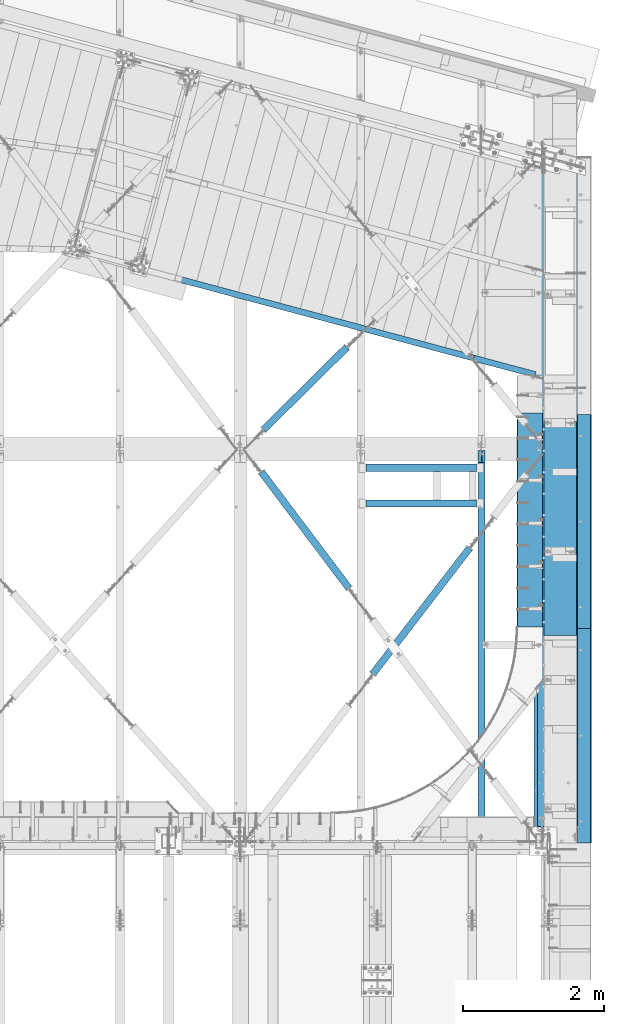
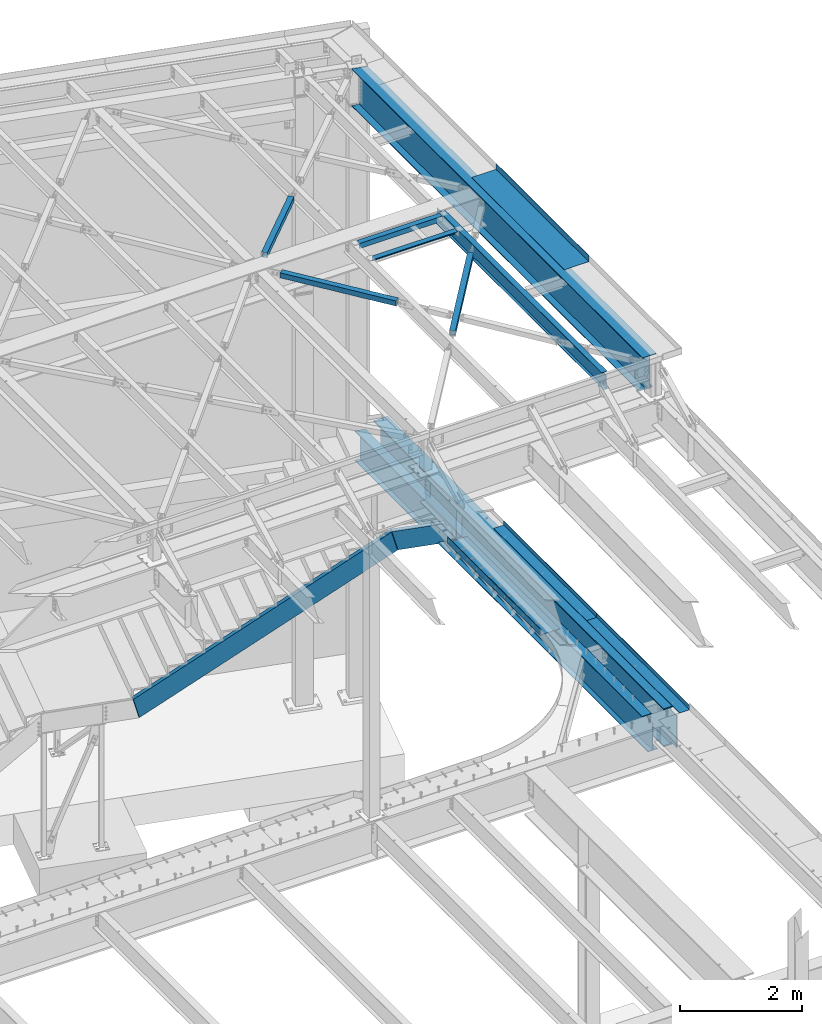
# One storey, part 1169 of 1763: 14 beams, 1 member, 9 elements without a shape of their own.
"""IFC2X3 building model written with IfcOpenShell, lengths in millimetres."""

from ifc_helpers import new_model, si_unit, frame, origin_with_axes, place, context, subcontext, project, spatial, faceted_brep, material, type_object, element, aggregate, save


model = new_model("IFC2X3")

# Units and contexts
model_context = context("Model", 3, precision=1e-05, world=origin_with_axes())
body_context = subcontext(model_context, "Body", "Model", "MODEL_VIEW")
ifc_project = project(units=[si_unit("LENGTHUNIT", "METRE", prefix="MILLI"), si_unit("AREAUNIT", "SQUARE_METRE"), si_unit("VOLUMEUNIT", "CUBIC_METRE"), si_unit("MASSUNIT", "GRAM", prefix="KILO"), si_unit("TIMEUNIT", "SECOND"), si_unit("PLANEANGLEUNIT", "RADIAN"), si_unit("SOLIDANGLEUNIT", "STERADIAN"), si_unit("THERMODYNAMICTEMPERATUREUNIT", "DEGREE_CELSIUS"), si_unit("LUMINOUSINTENSITYUNIT", "LUMEN")], contexts=[model_context])

# Site, building, storey
site_placement = place(None, origin_with_axes())
site = spatial("IfcSite", under=ifc_project, at=site_placement, CompositionType="ELEMENT")
building_placement = place(site_placement, origin_with_axes())
building = spatial("IfcBuilding", under=site, at=building_placement, Name="Undefined", CompositionType="ELEMENT")
storey_placement = place(building_placement, origin_with_axes())
storey = spatial("IfcBuildingStorey", under=building, at=storey_placement, Name="Undefined", CompositionType="ELEMENT", Elevation=0.0)

# Assembly, beams
assembly_1_placement = place(storey_placement, origin_with_axes())
assembly_1 = element("IfcElementAssembly", 1, at=assembly_1_placement, inside=storey, Name="FRAME", AssemblyPlace="NOTDEFINED", PredefinedType="RIGID_FRAME")
ifc_material_1 = material(Name="STEEL/A36")
beam_type_1 = type_object("IfcBeamType", Name="L4X4X3/8", PredefinedType="NOTDEFINED")
beam_1_placement = place(assembly_1_placement, frame((-24191.6246174484, 56926.1625, 12395.2), z_axis=(0.0, -1.0, 0.0), x_axis=(1.0, 0.0, 0.0)))
beam_1 = element("IfcBeam", 2, at=beam_1_placement, type_object=beam_type_1, material=ifc_material_1, Name="FRAME", ObjectType="L4X4X3/8", context=body_context, shape_type="Brep", body=[
    faceted_brep([(-3.63797880709171e-11, 50.8000000000011, -50.8000000000538), (-1.96450855582952e-10, 50.8000000000393, 50.7999999999374), (1572.27, 50.7999999999993, 50.8000000000029), (1572.27, 50.7999999999993, -50.8000000000029), (0.0, 41.2749999999996, 50.7999999999993), (1572.27, 41.2749999999996, 50.8000000000029), (0.0, 41.2749999999996, -41.2750000000015), (1572.27, 41.2749999999996, -41.2750000000015), (0.0, -50.7999999999993, -41.2750000000015), (1572.27, -50.7999999999993, -41.2750000000015), (2.11002770811319e-10, -50.8000000000357, -50.799999999952), (1572.27, -50.7999999999993, -50.8000000000029)], [[[0, 1, 2, 3]], [[1, 4, 5, 2]], [[4, 6, 7, 5]], [[6, 8, 9, 7]], [[8, 10, 11, 9]], [[10, 0, 3, 11]], [[5, 7, 9, 11, 3, 2]], [[10, 8, 6, 4, 1, 0]]]),
])
beam_2_placement = place(assembly_1_placement, frame((-24191.6246174484, 57434.1625, 12395.2), z_axis=(0.0, 0.0, -1.0), x_axis=(1.0, 0.0, 0.0)))
beam_2 = element("IfcBeam", 3, at=beam_2_placement, type_object=beam_type_1, material=ifc_material_1, Name="ANGLE", ObjectType="L4X4X3/8", context=body_context, shape_type="Brep", body=[
    faceted_brep([(-3.63797880709171e-11, 50.8000000000011, -50.8000000000538), (-1.96450855582952e-10, 50.8000000000393, 50.7999999999374), (1572.27, 50.7999999999993, 50.8000000000029), (1572.27, 50.7999999999993, -50.8000000000029), (0.0, 41.2749999999996, 50.7999999999993), (1572.27, 41.2749999999996, 50.8000000000029), (0.0, 41.2749999999996, -41.2750000000015), (1572.27, 41.2749999999996, -41.2750000000015), (0.0, -50.7999999999993, -41.2750000000015), (1572.27, -50.7999999999993, -41.2750000000015), (2.11002770811319e-10, -50.8000000000357, -50.799999999952), (1572.27, -50.7999999999993, -50.8000000000029)], [[[0, 1, 2, 3]], [[1, 4, 5, 2]], [[4, 6, 7, 5]], [[6, 8, 9, 7]], [[8, 10, 11, 9]], [[10, 0, 3, 11]], [[5, 7, 9, 11, 3, 2]], [[10, 8, 6, 4, 1, 0]]]),
])
aggregate(assembly_1, [beam_1, beam_2])

# Assembly, beam
assembly_2_placement = place(storey_placement, origin_with_axes())
assembly_2 = element("IfcElementAssembly", 4, at=assembly_2_placement, inside=storey, Name="H. BRACE", AssemblyPlace="NOTDEFINED", PredefinedType="RIGID_FRAME")
ifc_material_2 = material()
beam_type_2 = type_object("IfcBeamType", Name="HSS4X4X3/8", PredefinedType="NOTDEFINED")
beam_3_placement = place(assembly_2_placement, frame((-24264.6496174484, 55497.4369522237, 12371.3875), z_axis=(-0.798711499075791, -0.601714169057122, 0.0), x_axis=(-0.601714169057124, 0.798711499075789, 0.0)))
beam_3 = element("IfcBeam", 5, at=beam_3_placement, type_object=beam_type_2, material=ifc_material_2, Name="H. BRACE", ObjectType="HSS4X4X3/8", context=body_context, shape_type="Brep", body=[
    faceted_brep([(281.529879994538, 41.2749999999996, -41.2749999998341), (281.529879994538, -41.2749999999996, -41.2749999998341), (2347.5658130915, -41.2749999999996, -41.2749999993466), (2347.5658130915, 41.2749999999996, -41.2749999993466), (281.529879994778, -41.2749999999996, 41.2749999999724), (2347.56581309174, -41.2749999999996, 41.2750000004635), (281.529879994778, 41.2749999999996, 41.2749999999724), (2347.56581309174, 41.2749999999996, 41.2750000004635), (281.529879994509, 50.7999999999993, -50.7999999998101), (281.529879994807, 50.7999999999993, 50.7999999999593), (2347.56581309176, 50.7999999999993, 50.8000000004358), (2347.56581309147, 50.7999999999993, -50.7999999993335), (281.529879994807, -50.7999999999993, 50.7999999999593), (2347.56581309176, -50.7999999999993, 50.8000000004358), (281.529879994509, -50.7999999999993, -50.7999999998101), (2347.56581309147, -50.7999999999993, -50.7999999993335)], [[[0, 1, 2, 3]], [[1, 4, 5, 2]], [[4, 6, 7, 5]], [[6, 0, 3, 7]], [[8, 9, 10, 11]], [[9, 12, 13, 10]], [[12, 14, 15, 13]], [[14, 8, 11, 15]], [[13, 15, 11, 10], [5, 7, 3, 2]], [[14, 12, 9, 8], [6, 4, 1, 0]]]),
])
aggregate(assembly_2, [beam_3])

assembly_3_placement = place(storey_placement, origin_with_axes())
assembly_3 = element("IfcElementAssembly", 6, at=assembly_3_placement, inside=storey, Name="H. BRACE", AssemblyPlace="NOTDEFINED", PredefinedType="RIGID_FRAME")
beam_4_placement = place(assembly_3_placement, frame((-24264.6496174484, 54279.6635626025, 12371.3875), z_axis=(0.0, 0.0, 1.0), x_axis=(0.609825086268862, 0.792536033349383, 0.0)))
beam_4 = element("IfcBeam", 7, at=beam_4_placement, type_object=beam_type_2, material=ifc_material_2, Name="H. BRACE", ObjectType="HSS4X4X3/8", context=body_context, shape_type="Brep", body=[
    faceted_brep([(701.711262026362, 50.8000000008105, 4.76250000000073), (699.082205753217, 41.2750000008091, 4.76250000000073), (699.082205753217, 41.2750000008091, -4.76250000000073), (701.711262026362, 50.8000000008105, -4.76250000000073), (844.00607578101, 41.2750000009983, -4.76250000000073), (846.635132050567, 50.8000000009852, -4.76250000000073), (844.00607578101, 41.2750000009983, 4.76250000000073), (846.635132050567, 50.8000000009852, 4.76250000000073), (676.297051386016, -41.274999999092, 4.76250000000073), (673.667995112879, -50.7999999990789, 4.76250000000073), (673.667995112879, -50.7999999990789, -4.76250000000073), (676.297051386016, -41.274999999092, -4.76250000000073), (818.591865175276, -50.7999999988897, -4.76250000000073), (821.220921444834, -41.2749999989101, -4.76250000000073), (818.591865175276, -50.7999999988897, 4.76250000000073), (821.220921444834, -41.2749999989101, 4.76250000000073), (281.393808527577, -50.7999999995736, -50.7999999999993), (281.393808527511, 50.8000000002721, -50.7999999999993), (2536.37943236088, 50.8000000031243, -50.7999999999993), (2536.37943236095, -50.7999999967215, -50.7999999999993), (281.393808527511, 50.8000000002721, 50.7999999999993), (281.393808527577, -50.7999999995736, 50.7999999999993), (2536.37943236095, -50.7999999967215, 50.7999999999993), (2536.37943236088, 50.8000000031243, 50.7999999999993), (281.393808527519, 41.2750000002852, 41.2749999999996), (281.393808527569, -41.274999999594, 41.2749999999996), (281.393808527569, -41.274999999594, -41.2749999999996), (281.393808527519, 41.2750000002852, -41.2749999999996), (2536.37943236089, 41.2750000031374, -41.2749999999996), (2536.37943236089, 41.2750000031374, 41.2749999999996), (2536.37943236094, -41.2749999967346, 41.2749999999996), (2536.37943236094, -41.2749999967346, -41.2749999999996)], [[[0, 1, 2, 3]], [[3, 2, 4, 5]], [[5, 4, 6, 7]], [[7, 6, 1, 0]], [[8, 9, 10, 11]], [[11, 10, 12, 13]], [[13, 12, 14, 15]], [[15, 14, 9, 8]], [[16, 17, 18, 19]], [[20, 21, 22, 23]], [[17, 20, 23, 18], [3, 5, 7, 0]], [[16, 21, 20, 17], [24, 25, 26, 27]], [[24, 27, 28, 29], [2, 1, 6, 4]], [[25, 24, 29, 30]], [[26, 25, 30, 31], [11, 13, 15, 8]], [[27, 26, 31, 28]], [[22, 19, 18, 23], [30, 29, 28, 31]], [[21, 16, 19, 22], [10, 9, 14, 12]]]),
])
aggregate(assembly_3, [beam_4])

assembly_4_placement = place(storey_placement, origin_with_axes())
assembly_4 = element("IfcElementAssembly", 8, at=assembly_4_placement, inside=storey, Name="H. BRACE", AssemblyPlace="NOTDEFINED", PredefinedType="RIGID_FRAME")
beam_5_placement = place(assembly_4_placement, frame((-25925.8096172671, 57702.4499998193, 12371.3875), z_axis=(0.0, 0.0, 1.0), x_axis=(0.711007281992602, 0.703184644992688, 0.0)))
beam_5 = element("IfcBeam", 9, at=beam_5_placement, type_object=beam_type_2, material=ifc_material_2, Name="H. BRACE", ObjectType="HSS4X4X3/8", context=body_context, shape_type="Brep", body=[
    faceted_brep([(389.272124106836, 41.2749999993321, -41.2749999999996), (389.27212410705, -41.2750000006999, -41.2749999999996), (2055.81382714167, -41.2750000036322, -41.2749999999996), (2055.81382714145, 41.2749999964071, -41.2749999999996), (389.27212410705, -41.2750000006999, 41.2749999999996), (2055.81382714167, -41.2750000036322, 41.2749999999996), (389.272124106836, 41.2749999993321, 41.2749999999996), (2055.81382714145, 41.2749999964071, 41.2749999999996), (389.27212410681, 50.7999999993408, -50.7999999999993), (389.27212410681, 50.7999999993408, 50.7999999999993), (2055.81382714143, 50.7999999964159, 50.7999999999993), (2055.81382714143, 50.7999999964159, -50.7999999999993), (389.272124107076, -50.8000000007087, 50.7999999999993), (2055.8138271417, -50.8000000036409, 50.7999999999993), (389.272124107076, -50.8000000007087, -50.7999999999993), (2055.8138271417, -50.8000000036409, -50.7999999999993)], [[[0, 1, 2, 3]], [[1, 4, 5, 2]], [[4, 6, 7, 5]], [[6, 0, 3, 7]], [[8, 9, 10, 11]], [[9, 12, 13, 10]], [[12, 14, 15, 13]], [[14, 8, 11, 15]], [[13, 15, 11, 10], [5, 7, 3, 2]], [[14, 12, 9, 8], [6, 4, 1, 0]]]),
])
aggregate(assembly_4, [beam_5])

assembly_5_placement = place(storey_placement, origin_with_axes())
assembly_5 = element("IfcElementAssembly", 10, at=assembly_5_placement, inside=storey, Name="BEAM", AssemblyPlace="NOTDEFINED", PredefinedType="RIGID_FRAME")
beam_type_3 = type_object("IfcBeamType", PredefinedType="NOTDEFINED")
beam_6_placement = place(assembly_5_placement, frame((-21657.3396174483, 56572.15, 12449.175), z_axis=(0.0, -1.0, 0.0), x_axis=(1.0, 0.0, 0.0)))
beam_6 = element("IfcBeam", 11, at=beam_6_placement, type_object=beam_type_3, material=ifc_material_1, Name="BENT_PLATE", context=body_context, shape_type="Brep", body=[
    faceted_brep([(0.0, -3.17499999999927, -1523.99999999999), (0.0, -3.17499999999927, 1524.0), (0.0, 3.17499999999927, 1524.0), (0.0, 3.17499999999927, -1523.99999999999), (460.375006103517, 3.17499999999927, 1524.0), (460.375006103517, 3.17499999999927, -1524.0), (466.725006103516, -3.17499999999927, -1524.0), (466.725006103516, -3.17499999999927, 1524.0), (460.375006103517, 123.825000000001, 1524.0), (460.375006103517, 123.825000000001, -1524.0), (466.725006103516, 123.825000000001, 1524.0), (466.725006103516, 123.825000000001, -1524.0)], [[[0, 1, 2, 3]], [[3, 2, 4, 5]], [[1, 0, 6, 7]], [[5, 4, 8, 9]], [[4, 2, 1, 7, 10, 8]], [[7, 6, 11, 10]], [[6, 0, 3, 5, 9, 11]], [[10, 11, 9, 8]]]),
])

# Assembly, beam, member
assembly_6_placement = place(storey_placement, origin_with_axes())
assembly_6 = element("IfcElementAssembly", 12, at=assembly_6_placement, inside=storey, Name="STRINGER", AssemblyPlace="NOTDEFINED", PredefinedType="RIGID_FRAME")
beam_type_4 = type_object("IfcBeamType", Name="C15X33.9", PredefinedType="NOTDEFINED")
beam_7_placement = place(assembly_6_placement, frame((-22632.678377773, 58987.7868004922, 5003.79999995455), z_axis=(0.0, 0.0, -1.0), x_axis=(0.965913267114843, -0.258865912030785, 0.0)))
beam_7 = element("IfcBeam", 13, at=beam_7_placement, type_object=beam_type_4, material=ifc_material_1, Name="STRINGER", ObjectType="C15X33.9", context=body_context, shape_type="Brep", body=[
    faceted_brep([(883.505280899408, 33.3374999994412, -169.0709725), (883.505280899379, -42.8625000005559, -181.7658925), (883.505280899386, -42.8625000005559, -190.5), (883.505280899437, 42.8624999994427, -190.5), (883.505280899415, 42.8624999994354, -165.099999808838), (883.505280899408, 33.3374999994412, -165.099999808838), (884.472010821999, 42.8624999994427, -160.239920290787), (884.472010821992, 33.3374999994412, -160.239920290787), (887.22502472248, 42.8624999994354, -156.119743822628), (887.225024722473, 33.3374999994412, -156.119743822628), (891.345201190634, 42.8624999994354, -153.366729922148), (891.345201190634, 33.3374999994339, -153.366729922148), (896.205280708687, 42.8624999994281, -152.399999999562), (896.20528070868, 33.3374999994267, -152.399999999562), (996.592482215368, 42.8624999993699, -152.399999999654), (994.03977081152, 33.3374999993684, -152.399999999651), (77.1544915036648, -42.8625000000466, 190.5), (74.7932330348121, -42.8625000000466, 181.7658925), (756.505280899328, -42.8625000004758, 181.7658925), (756.505280899313, -42.8625000004758, 190.5), (756.505280899371, 19.0576241889066, 171.449999810048), (756.505280899386, 42.8624999995154, 171.449999810048), (756.505280899371, 42.8624999995227, 190.5), (77.154491503672, 42.8624999999447, 190.5), (-25.8485316026636, -42.8624999999811, -190.5), (-23.4872731338037, -42.8624999999884, -181.7658925), (-20.055212403895, 33.3375000000087, -169.0709725), (71.3611723049107, 33.3374999999505, 169.0709725), (-25.8485316026636, 42.8625000000102, -190.5), (756.978498853685, 33.3374999995212, 169.0709725), (757.472010821977, 33.3374999995212, 166.589920292006), (757.472010821977, 42.8624999995154, 166.589920292006), (760.225024722451, 33.337499999514, 162.469743823857), (760.225024722458, 42.8624999995154, 162.469743823857), (764.345201190605, 33.337499999514, 159.716729923382), (764.345201190612, 42.8624999995154, 159.716729923382), (769.205280708644, 33.337499999514, 158.750000000796), (769.205280708651, 42.8624999995154, 158.750000000796), (996.592482215368, 42.8624999993699, 158.750000000796), (994.03977081152, 33.3374999993684, 158.750000000796)], [[[0, 1, 2, 3, 4, 5]], [[5, 4, 6, 7]], [[7, 6, 8, 9]], [[9, 8, 10, 11]], [[11, 10, 12, 13]], [[14, 15, 13, 12]], [[16, 17, 18, 19]], [[19, 18, 20, 21, 22]], [[23, 16, 19, 22]], [[24, 25, 26, 27, 17, 16, 23, 28]], [[18, 17, 27, 29, 20]], [[30, 31, 21, 20, 29]], [[32, 33, 31, 30]], [[34, 35, 33, 32]], [[36, 37, 35, 34]], [[38, 37, 36, 39]], [[10, 8, 6, 4, 3, 28, 23, 22, 21, 31, 33, 35, 37, 38, 14, 12]], [[24, 28, 3, 2]], [[25, 24, 2, 1]], [[26, 25, 1, 0]], [[39, 36, 34, 32, 30, 29, 27, 26, 0, 5, 7, 9, 11, 13, 15]], [[38, 39, 15, 14]]]),
])
member_type = type_object("IfcMemberType", Name="C15X33.9", PredefinedType="NOTDEFINED")
member_placement = place(assembly_6_placement, frame((-27333.3267074109, 60247.5661804874, 2150.02511936823), z_axis=(0.486695708763338, -0.13043503320458, -0.863778900636194), x_axis=(0.834335499956352, -0.223602912988303, 0.50387102597364)))
member = element("IfcMember", 14, at=member_placement, type_object=member_type, material=ifc_material_1, Name="STRINGER", ObjectType="C15X33.9", context=body_context, shape_type="Brep", body=[
    faceted_brep([(523.303161364282, -40.0966168604136, 181.305096368353), (523.303161298711, 33.3374999990774, 181.305096368342), (526.610646191919, 33.337499999041, 169.070972499583), (5712.71677020475, -40.0966168626983, -181.305096369731), (5712.71677022149, 33.3374999838925, -181.305096369739), (5709.40928534023, 33.3374999839289, -169.070972503134), (5602.6745816897, -42.8625000150787, 190.4999999967), (5614.08350147108, -42.8625000151369, 181.7658924967), (5614.68541599147, -40.096616861556, 181.30509636331), (5614.68541600821, 33.3374999850275, 181.305096363307), (5602.67458170917, 42.5324036184975, 190.499999996689), (5705.67760452474, 42.5324036172969, -190.500000003118), (5705.33565772283, 42.8624999839012, -190.500000003118), (5602.33263490726, 42.862499985109, 190.499999996689), (5617.99290088947, 33.3374999849839, 169.070972496695), (5712.36400736227, -42.8625000162865, -181.765892503117), (5705.67760450527, -42.8625000162865, -190.500000003107), (633.345350226991, -42.8625000022876, -190.500000000229), (621.93643043538, -42.8625000022439, -181.765892500229), (621.334515915427, -40.096616861556, -181.305096368997), (621.334515849863, 33.3374999979278, -181.305096369004), (633.345350150754, 42.5324036291422, -190.50000000024), (530.342326981394, 42.5324036303355, 190.499999999567), (530.684273785395, 42.8624999991007, 190.499999999567), (633.687296954748, 42.8624999979002, -190.50000000024), (618.027030956662, 33.3374999979787, -169.070972500245), (523.655924206636, -42.8625000010943, 181.765892499589), (530.342327057631, -42.862500001087, 190.499999999574)], [[[0, 1, 2]], [[3, 4, 5]], [[6, 7, 8, 9, 10]], [[4, 11, 12, 13, 10, 9, 14, 5]], [[3, 15, 16, 11, 4]], [[17, 18, 19, 20, 21]], [[1, 22, 23, 24, 21, 20, 25, 2]], [[0, 26, 27, 22, 1]], [[24, 23, 13, 12]], [[13, 23, 22, 27, 6, 10]], [[27, 26, 7, 6]], [[26, 0, 2, 14, 8, 7]], [[2, 25, 5, 14]], [[5, 25, 19, 18, 15, 3]], [[18, 17, 16, 15]], [[16, 17, 21, 24, 12, 11]], [[8, 14, 9]], [[19, 25, 20]]]),
])
aggregate(assembly_6, [beam_7, member])

# Assembly, beam
assembly_7_placement = place(storey_placement, origin_with_axes())
assembly_7 = element("IfcElementAssembly", 15, at=assembly_7_placement, inside=storey, Name="BEAM", AssemblyPlace="NOTDEFINED", PredefinedType="RIGID_FRAME")
beam_type_5 = type_object("IfcBeamType", PredefinedType="NOTDEFINED")
beam_8_placement = place(assembly_7_placement, frame((-22039.9003518186, 56692.7996159619, 5321.3), z_axis=(0.0, -1.0, 0.0), x_axis=(0.0, 0.0, -1.0)))
beam_8 = element("IfcBeam", 16, at=beam_8_placement, type_object=beam_type_5, material=ifc_material_1, Name="BENT PLATE", context=body_context, shape_type="Brep", body=[
    faceted_brep([(0.0, -4.76249999999982, -1524.0), (0.0, -4.76249999999982, 1524.0), (0.0, 4.76249999999982, 1524.0), (0.0, 4.76249999999982, -1524.0), (117.474999999999, 4.76250000000073, 1524.0), (117.474999999999, 4.76250000000073, -1524.0), (126.999999999999, -4.76250000000073, -1524.0), (126.999999999999, -4.76250000000073, 1524.0), (117.474999999999, 363.490643310546, 1524.0), (117.474999999999, 363.490643310546, -1524.0), (126.999999999999, 363.490643310546, 1524.0), (126.999999999999, 363.490643310546, -1524.0)], [[[0, 1, 2, 3]], [[3, 2, 4, 5]], [[1, 0, 6, 7]], [[5, 4, 8, 9]], [[4, 2, 1, 7, 10, 8]], [[7, 6, 11, 10]], [[6, 0, 3, 5, 9, 11]], [[10, 11, 9, 8]]]),
])

# Assembly, beams
assembly_8_placement = place(storey_placement, origin_with_axes())
assembly_8 = element("IfcElementAssembly", 17, at=assembly_8_placement, inside=storey, Name="BEAM", AssemblyPlace="NOTDEFINED", PredefinedType="RIGID_FRAME")
beam_type_6 = type_object("IfcBeamType", PredefinedType="NOTDEFINED")
beam_9_placement = place(assembly_8_placement, frame((-21181.0896174484, 56669.781, 5199.0625), z_axis=(0.0, -1.0, 0.0), x_axis=(1.0, 0.0, 0.0)))
beam_9 = element("IfcBeam", 18, at=beam_9_placement, type_object=beam_type_6, material=ifc_material_1, Name="BENT PLATE", context=body_context, shape_type="Brep", body=[
    faceted_brep([(0.0, -4.76249999999982, -1524.0), (0.0, -4.76249999999982, 1524.0), (0.0, 4.76249999999982, 1524.0), (0.0, 4.76249999999982, -1524.0), (187.325021362303, 4.76249999999982, 1524.0), (187.325021362303, 4.76249999999982, -1524.0), (196.850021362305, -4.76249999999982, -1524.0), (196.850021362305, -4.76249999999982, 1524.0), (187.325021362303, 84.1374938964846, 1524.0), (187.325021362303, 84.1374938964846, -1524.0), (196.850021362305, 84.1374938964846, 1524.0), (196.850021362305, 84.1374938964846, -1524.0)], [[[0, 1, 2, 3]], [[3, 2, 4, 5]], [[1, 0, 6, 7]], [[5, 4, 8, 9]], [[4, 2, 1, 7, 10, 8]], [[7, 6, 11, 10]], [[6, 0, 3, 5, 9, 11]], [[10, 11, 9, 8]]]),
])
beam_10_placement = place(assembly_8_placement, frame((-21181.0896174484, 53621.781, 5199.0625), z_axis=(0.0, -1.0, 0.0), x_axis=(1.0, 0.0, 0.0)))
beam_10 = element("IfcBeam", 19, at=beam_10_placement, type_object=beam_type_6, material=ifc_material_1, Name="BENT PLATE", context=body_context, shape_type="Brep", body=[
    faceted_brep([(0.0, -4.76249999999982, -1524.0), (0.0, -4.76249999999982, 1524.0), (0.0, 4.76249999999982, 1524.0), (0.0, 4.76249999999982, -1524.0), (187.325021362303, 4.76249999999982, 1524.0), (187.325021362303, 4.76249999999982, -1524.0), (196.850021362305, -4.76249999999982, -1524.0), (196.850021362305, -4.76249999999982, 1524.0), (187.325021362303, 84.1374938964846, 1524.0), (187.325021362303, 84.1374938964846, -1524.0), (196.850021362305, 84.1374938964846, 1524.0), (196.850021362305, 84.1374938964846, -1524.0)], [[[0, 1, 2, 3]], [[3, 2, 4, 5]], [[1, 0, 6, 7]], [[5, 4, 8, 9]], [[4, 2, 1, 7, 10, 8]], [[7, 6, 11, 10]], [[6, 0, 3, 5, 9, 11]], [[10, 11, 9, 8]]]),
])

# Assembly, beam
assembly_9_placement = place(storey_placement, origin_with_axes())
assembly_9 = element("IfcElementAssembly", 20, at=assembly_9_placement, inside=storey, Name="BEAM", AssemblyPlace="NOTDEFINED", PredefinedType="RIGID_FRAME")
ifc_material_3 = material(Name="STEEL/A992")
beam_type_7 = type_object("IfcBeamType", Name="W12X16", PredefinedType="NOTDEFINED")
beam_11_placement = place(assembly_9_placement, frame((-22546.3296174484, 52120.8, 12293.6), z_axis=(0.0, 0.0, 1.0), x_axis=(0.0, 1.0, 0.0)))
beam_11 = element("IfcBeam", 21, at=beam_11_placement, type_object=beam_type_7, material=ifc_material_3, Name="BEAM", ObjectType="W12X16", context=body_context, shape_type="Brep", body=[
    faceted_brep([(63.5000001907174, -3.17499999999927, 126.740001678467), (63.5000001907174, 3.17499999999927, 126.740001678467), (15.8749999999854, 3.17499999999927, 126.740001678467), (15.8749999999854, -3.17499999999927, 126.740001678467), (68.3600797087638, -3.17499999999927, 127.706731601054), (68.3600797087638, 3.17499999999927, 127.706731601054), (72.4802561769175, -3.17499999999927, 130.459745501532), (72.4802561769175, 3.17499999999927, 130.459745501532), (75.2332700773914, -3.17499999999927, 134.579921969686), (75.2332700773914, 3.17499999999927, 134.579921969686), (76.1999999999825, -3.17499999999927, 139.440001487732), (76.1999999999825, 3.17499999999927, 139.440001487732), (76.1999999999825, -50.7999999999993, 152.4), (76.1999999999825, 50.7999999999993, 152.4), (76.1999999999825, 50.7999999999993, 146.049999999999), (76.1999999999825, 3.17499999999927, 146.049999999999), (76.1999999999825, -3.17499999999927, 146.049999999999), (76.1999999999825, -50.7999999999993, 146.049999999999), (15.8749999999854, -3.17499999999927, -146.049999999999), (15.8749999999854, -50.7999999999993, -146.049999999999), (5561.01249999999, -50.7999999999993, -146.049999999999), (5561.01249999999, -3.17499999999927, -146.049999999999), (15.8749999999854, -50.7999999999993, -152.4), (5561.01249999999, -50.7999999999993, -152.4), (15.8749999999854, 50.7999999999993, -152.4), (5561.01249999999, 50.7999999999993, -152.4), (15.8749999999854, 50.7999999999993, -146.049999999999), (5561.01249999999, 50.7999999999993, -146.049999999999), (15.8749999999854, 3.17499999999927, -146.049999999999), (5561.01249999999, 3.17499999999927, -146.049999999999), (5561.01249999999, 3.17499999999927, 114.040001678466), (5561.01249999999, -3.17499999999927, 114.040001678466), (5402.26249980926, 3.17499999999927, 114.040001678466), (5402.26249980926, -3.17499999999927, 114.040001678466), (5397.40242029121, 3.17499999999927, 115.006731601054), (5397.40242029121, -3.17499999999927, 115.006731601054), (5393.28224382306, 3.17499999999927, 117.759745501531), (5393.28224382306, -3.17499999999927, 117.759745501531), (5390.52922992258, 3.17499999999927, 121.879921969685), (5390.52922992258, -3.17499999999927, 121.879921969685), (5389.56249999999, 3.17499999999927, 126.740001487731), (5389.56249999999, -3.17499999999927, 126.740001487731), (5389.56249999999, -50.7999999999993, 152.4), (5389.56249999999, -50.7999999999993, 146.049999999999), (5389.56249999999, -3.17499999999927, 146.049999999999), (5389.56249999999, 3.17499999999927, 146.049999999999), (5389.56249999999, 50.7999999999993, 146.049999999999), (5389.56249999999, 50.7999999999993, 152.4)], [[[0, 1, 2, 3]], [[4, 5, 1, 0]], [[6, 7, 5, 4]], [[8, 9, 7, 6]], [[10, 11, 9, 8]], [[12, 13, 14, 15, 11, 10, 16, 17]], [[18, 19, 20, 21]], [[19, 22, 23, 20]], [[22, 24, 25, 23]], [[24, 26, 27, 25]], [[26, 28, 29, 27]], [[21, 20, 23, 25, 27, 29, 30, 31]], [[31, 30, 32, 33]], [[33, 32, 34, 35]], [[35, 34, 36, 37]], [[37, 36, 38, 39]], [[39, 38, 40, 41]], [[42, 43, 44, 41, 40, 45, 46, 47]], [[43, 42, 12, 17]], [[44, 43, 17, 16]], [[8, 6, 4, 0, 3, 18, 21, 31, 33, 35, 37, 39, 41, 44, 16, 10]], [[28, 26, 24, 22, 19, 18, 3, 2]], [[45, 40, 38, 36, 34, 32, 30, 29, 28, 2, 1, 5, 7, 9, 11, 15]], [[46, 45, 15, 14]], [[47, 46, 14, 13]], [[42, 47, 13, 12]]]),
])
aggregate(assembly_9, [beam_11])

# Beam
beam_type_8 = type_object("IfcBeamType", Name="W24X55", PredefinedType="NOTDEFINED")
beam_12_placement = place(assembly_7_placement, frame((-21663.6896174484, 52120.8, 4894.2625), z_axis=(0.0, 0.0, 1.0), x_axis=(0.0, 1.0, 0.0)))
beam_12 = element("IfcBeam", 22, at=beam_12_placement, type_object=beam_type_8, material=ifc_material_3, Name="BEAM", ObjectType="W24X55", context=body_context, shape_type="Brep", body=[
    faceted_brep([(23.0187500000029, -4.76250000000073, -287.3375), (23.0187500000029, -88.9000000000015, -287.3375), (9593.05383183486, -88.9000000000015, -287.3375), (9615.60278256886, -4.76250000000073, -287.3375), (23.0187500000029, -88.9000000000015, -300.0375), (9593.05383183486, -88.9000000000015, -300.0375), (23.0187500000029, -4.93732006007122, -300.0375), (23.0187500000029, 83.9001815018673, -300.0375), (23.0187500000029, 88.9000000000015, -300.0375), (9640.7044447067, 88.9000000000015, -300.0375), (23.0187500000029, 88.9000000000015, -287.3375), (9640.7044447067, 88.9000000000015, -287.3375), (9618.1554939727, 4.76250000000073, -287.3375), (9618.1554939727, 4.76250000000073, 287.3375), (9640.7044447067, 88.9000000000015, 287.3375), (9640.7044447067, 88.9000000000015, 300.0375), (9593.05383183486, -88.9000000000015, 300.0375), (9593.05383183486, -88.9000000000015, 287.3375), (9615.60278256886, -4.76250000000073, 287.3375), (23.0187500000029, 83.8998184977754, -287.3375), (23.0187500000029, 4.76250000000073, -287.3375), (199.328829708786, -4.76250000000073, 243.594227786357), (199.328829708786, 4.76250000000073, 243.594227786357), (194.468750190739, 4.76250000000073, 242.627497863769), (194.468750190739, -4.76250000000073, 242.627497863769), (203.449006176939, -4.76250000000073, 246.347241686835), (203.449006176939, 4.76250000000073, 246.347241686835), (206.202020077413, -4.76250000000073, 250.467418154989), (206.202020077413, 4.76250000000073, 250.467418154989), (207.168750000004, -4.76250000000073, 255.327497673034), (207.168750000004, 4.76250000000073, 255.327497673034), (23.0187500000029, 4.76250000000073, -278.63990489734), (23.0187500000029, 4.76250000000073, 242.627497863769), (207.168750000004, 4.76250000000073, 287.3375), (207.168750000004, 88.9000000000015, 287.3375), (207.168750000004, 88.9000000000015, 300.0375), (207.168750000004, -88.9000000000015, 300.0375), (207.168750000004, -88.9000000000015, 287.3375), (207.168750000004, -4.76250000000073, 287.3375), (23.0187500000029, -4.76250000000073, 242.627497863769), (23.0187500000029, -4.76250000000073, -278.64018216478)], [[[0, 1, 2, 3]], [[1, 4, 5, 2]], [[4, 6, 7, 8, 9, 5]], [[8, 10, 11, 9]], [[12, 13, 14, 15, 16, 17, 18, 3, 2, 5, 9, 11]], [[10, 19, 20, 12, 11]], [[21, 22, 23, 24]], [[25, 26, 22, 21]], [[27, 28, 26, 25]], [[29, 30, 28, 27]], [[13, 12, 20, 31, 32, 23, 22, 26, 28, 30, 33]], [[14, 13, 33, 34]], [[15, 14, 34, 35]], [[16, 15, 35, 36]], [[17, 16, 36, 37]], [[18, 17, 37, 38]], [[36, 35, 34, 33, 30, 29, 38, 37]], [[27, 25, 21, 24, 39, 40, 0, 3, 18, 38, 29]], [[31, 20, 19, 10, 8, 7, 6, 4, 1, 0, 40, 39, 32]], [[24, 23, 32, 39]]]),
])

aggregate(assembly_7, [beam_8, beam_12])

beam_type_9 = type_object("IfcBeamType", Name="W30X116", PredefinedType="NOTDEFINED")
beam_13_placement = place(assembly_8_placement, frame((-21206.4896174484, 52120.8, 4813.3), z_axis=(0.0, 0.0, 1.0), x_axis=(0.0, 1.0, 0.0)))
beam_13 = element("IfcBeam", 23, at=beam_13_placement, type_object=beam_type_9, material=ifc_material_3, Name="BEAM", ObjectType="W30X116", context=body_context, shape_type="Brep", body=[
    faceted_brep([(23.0187499999956, -7.14374999999927, -324.11), (23.0187499999956, 7.14374999999927, -324.11), (207.168750190729, 7.14374999999927, -324.11), (207.168750190729, -7.14374999999927, -324.11), (212.028829708775, 7.14374999999927, -325.076729922587), (212.028829708775, -7.14374999999927, -325.076729922587), (216.149006176929, 7.14374999999927, -327.829743823066), (216.149006176929, -7.14374999999927, -327.829743823066), (218.902020077403, 7.14374999999927, -331.949920291219), (218.902020077403, -7.14374999999927, -331.949920291219), (219.868749999994, -7.14374999999927, -336.809999809265), (219.868749999994, 7.14374999999927, -336.809999809265), (219.868749999994, 7.14374999999927, -358.775), (219.868749999994, 133.349999999999, -358.775), (219.868749999994, 133.349999999999, -381.0), (219.868749999994, -133.349999999999, -381.0), (219.868749999994, -133.349999999999, -358.775), (219.868749999994, -7.14374999999927, -358.775), (9733.16093799999, -133.349999999999, 358.775), (9733.16093799999, -133.349999999999, 381.0), (219.868749999994, -133.349999999999, 381.0), (219.868749999994, -133.349999999999, 358.775), (9733.16093799999, 133.349999999999, 381.0), (219.868749999994, 133.349999999999, 381.0), (9733.16093799999, 133.349999999999, 358.775), (219.868749999994, 133.349999999999, 358.775), (9733.16093799999, 7.14374999999927, 358.775), (219.868749999994, 7.14374999999927, 358.775), (207.168750190729, -7.14374999999927, 323.58999786377), (207.168750190729, 7.14374999999927, 323.58999786377), (23.0187499999956, 7.14374999999927, 323.58999786377), (23.0187499999956, -7.14374999999927, 323.58999786377), (212.028829708775, -7.14374999999927, 324.556727786357), (212.028829708775, 7.14374999999927, 324.556727786357), (216.149006176929, -7.14374999999927, 327.309741686836), (216.149006176929, 7.14374999999927, 327.309741686836), (218.902020077403, -7.14374999999927, 331.42991815499), (218.902020077403, 7.14374999999927, 331.42991815499), (219.868749999994, -7.14374999999927, 336.289997673035), (219.868749999994, 7.14374999999927, 336.289997673035), (219.868749999994, -7.14374999999927, 358.775), (9733.16093799999, -7.14374999999927, 358.775), (9733.16093799999, 7.14374999999927, -358.775), (9733.16093799999, -7.14374999999927, -358.775), (9733.16093799999, -133.349999999999, -358.775), (9733.16093799999, -133.349999999999, -381.0), (9733.16093799999, 133.349999999999, -381.0), (9733.16093799999, 133.349999999999, -358.775)], [[[0, 1, 2, 3]], [[3, 2, 4, 5]], [[5, 4, 6, 7]], [[7, 6, 8, 9]], [[10, 11, 12, 13, 14, 15, 16, 17]], [[9, 8, 11, 10]], [[18, 19, 20, 21]], [[19, 22, 23, 20]], [[22, 24, 25, 23]], [[24, 26, 27, 25]], [[28, 29, 30, 31]], [[32, 33, 29, 28]], [[34, 35, 33, 32]], [[36, 37, 35, 34]], [[38, 39, 37, 36]], [[20, 23, 25, 27, 39, 38, 40, 21]], [[41, 18, 21, 40]], [[42, 26, 24, 22, 19, 18, 41, 43, 44, 45, 46, 47]], [[44, 43, 17, 16]], [[45, 44, 16, 15]], [[46, 45, 15, 14]], [[47, 46, 14, 13]], [[42, 47, 13, 12]], [[6, 4, 2, 1, 30, 29, 33, 35, 37, 39, 27, 26, 42, 12, 11, 8]], [[31, 30, 1, 0]], [[43, 41, 40, 38, 36, 34, 32, 28, 31, 0, 3, 5, 7, 9, 10, 17]]]),
])

aggregate(assembly_8, [beam_9, beam_10, beam_13])

beam_type_10 = type_object("IfcBeamType", Name="W30X90", PredefinedType="NOTDEFINED")
beam_14_placement = place(assembly_5_placement, frame((-21670.0396174483, 52019.2000000041, 12071.35), z_axis=(0.0, 0.0, 1.0), x_axis=(0.0, 1.0, 0.0)))
beam_14 = element("IfcBeam", 24, at=beam_14_placement, type_object=beam_type_10, material=ifc_material_3, Name="BEAM", ObjectType="W30X90", context=body_context, shape_type="Brep", body=[
    faceted_brep([(215.899999995891, -6.34999999999854, -292.100004577635), (215.899999995891, 6.34999999999854, -292.100004577635), (330.200000186633, 6.34999999999854, -292.100004577635), (330.200000186633, -6.34999999999854, -292.100004577635), (335.060079704679, 6.34999999999854, -293.066734500222), (335.060079704679, -6.34999999999854, -293.066734500222), (339.180256172833, 6.34999999999854, -295.8197484007), (339.180256172833, -6.34999999999854, -295.8197484007), (341.933270073307, 6.34999999999854, -299.939924868853), (341.933270073307, -6.34999999999854, -299.939924868853), (342.899999995898, -6.34999999999854, -304.8000043869), (342.899999995898, 6.34999999999854, -304.8000043869), (342.899999995898, 6.34999999999854, -358.775), (342.899999995898, 131.762500000001, -358.775), (342.899999995898, 131.762500000001, -374.65), (342.899999995898, -131.762500000001, -374.65), (342.899999995898, -131.762500000001, -358.775), (342.899999995898, -6.34999999999854, -358.775), (215.899999995891, 6.34999999999854, 358.775), (215.899999995891, 131.762500000001, 358.775), (9755.49345362471, 131.762500000001, 358.775), (9721.88275347403, 6.34999999999854, 358.775), (215.899999995891, 131.762500000001, 374.65), (9755.49345362471, 131.762500000001, 374.65), (215.899999995891, -131.762500000001, 374.65), (9684.86843811822, -131.762500000001, 374.65), (215.899999995891, -131.762500000001, 358.775), (9684.86843811822, -131.762500000001, 358.775), (215.899999995891, -6.34999999999854, 358.775), (9718.47913826889, -6.34999999999854, 358.775), (9721.88275347403, 6.34999999999854, -358.775), (9718.47913826889, -6.34999999999854, -358.775), (9684.86843811822, -131.762500000001, -358.775), (9684.86843811822, -131.762500000001, -374.65), (9755.49345362471, 131.762500000001, -374.65), (9755.49345362471, 131.762500000001, -358.775)], [[[0, 1, 2, 3]], [[3, 2, 4, 5]], [[5, 4, 6, 7]], [[7, 6, 8, 9]], [[10, 11, 12, 13, 14, 15, 16, 17]], [[9, 8, 11, 10]], [[18, 19, 20, 21]], [[19, 22, 23, 20]], [[22, 24, 25, 23]], [[24, 26, 27, 25]], [[26, 28, 29, 27]], [[30, 21, 20, 23, 25, 27, 29, 31, 32, 33, 34, 35]], [[32, 31, 17, 16]], [[33, 32, 16, 15]], [[34, 33, 15, 14]], [[35, 34, 14, 13]], [[30, 35, 13, 12]], [[6, 4, 2, 1, 18, 21, 30, 12, 11, 8]], [[28, 26, 24, 22, 19, 18, 1, 0]], [[31, 29, 28, 0, 3, 5, 7, 9, 10, 17]]]),
])

aggregate(assembly_5, [beam_6, beam_14])

save(model, "model.ifc")
